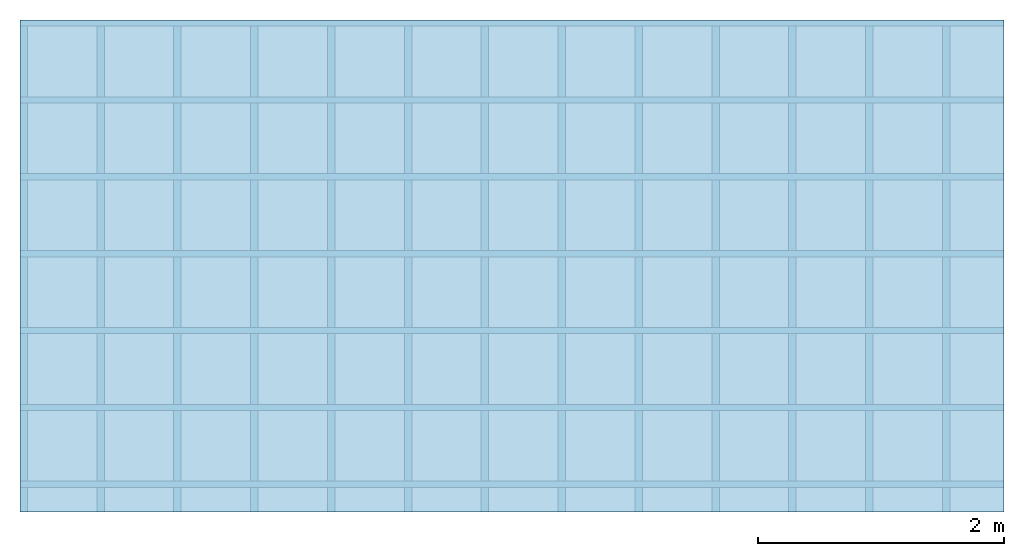
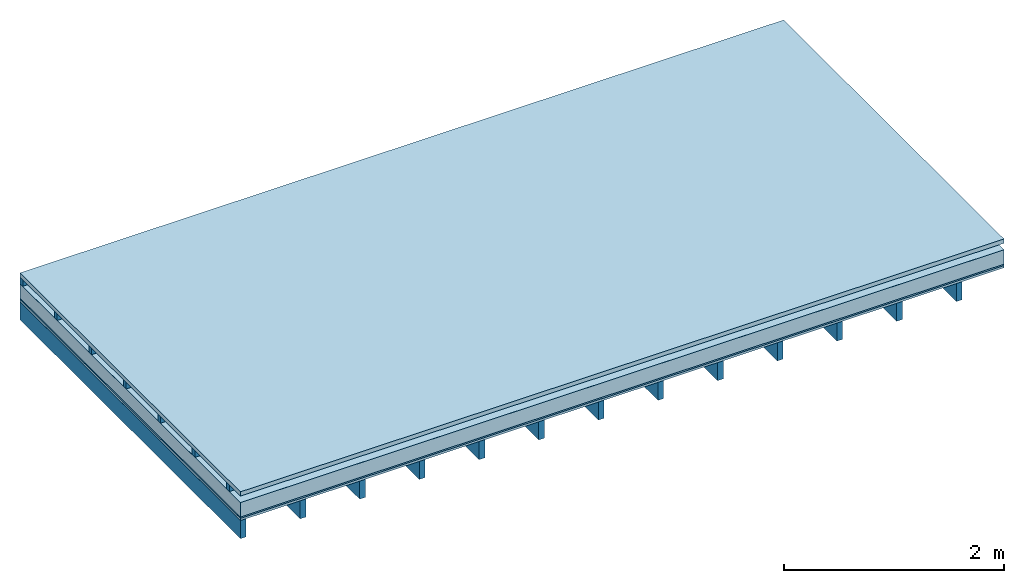
# One storey: 5 plates, 2 members, 1 element without a shape of its own.
"""IFC4 building model written with IfcOpenShell, lengths in metres."""

from ifc_helpers import new_model, si_unit, derived_unit, direction, frame, frame_2d, origin, origin_with_axes, place, context, project, spatial, rectangle, extrude, material, layer, layer_set, type_object, element, aggregate, save


model = new_model("IFC4")

# Units and contexts
plan_context = context("Plan", 3, precision=1e-05, world=origin(), true_north=direction((0.0, 1.0)))
model_context = context("Model", 3, precision=1e-05, world=origin(), true_north=direction((0.0, 1.0)))
ifc_project = project(units=[si_unit("LENGTHUNIT", "METRE"), derived_unit("SOUNDPRESSUREUNIT", [(si_unit("PRESSUREUNIT", "PASCAL", prefix="MICRO"), 0)]), si_unit("ENERGYUNIT", "JOULE", prefix="MEGA"), si_unit("MASSUNIT", "GRAM", prefix="KILO"), derived_unit("THERMALTRANSMITTANCEUNIT", [(si_unit("POWERUNIT", "WATT"), 1), (si_unit("AREAUNIT", "SQUARE_METRE"), -1), (si_unit("THERMODYNAMICTEMPERATUREUNIT", "KELVIN"), -1)]), derived_unit("AREADENSITYUNIT", [(si_unit("MASSUNIT", "GRAM", prefix="KILO"), 1), (si_unit("AREAUNIT", "SQUARE_METRE"), -1)]), derived_unit("USERDEFINED", [(si_unit("ENERGYUNIT", "JOULE", prefix="MEGA"), 1), (si_unit("AREAUNIT", "SQUARE_METRE"), -1)])], contexts=[plan_context, model_context])

# Site, building, storey
site = spatial("IfcSite", under=ifc_project)
building_placement = place(None, origin())
building = spatial("IfcBuilding", under=site, at=building_placement)
storey_placement = place(building_placement, origin())
storey = spatial("IfcBuildingStorey", under=building, at=storey_placement)

# Slab, members, plates
ifc_material_1 = material(Name="Roof tiles", Category="03.015")
ifc_layer_1 = layer(ifc_material_1, 0.047, Name="Roofing")
ifc_layer_2 = layer(None, 0.072, Name="Battens / profiles")
ifc_material_2 = material(Name="Roofing underlay", Category="09.008")
ifc_layer_3 = layer(ifc_material_2, 0.00018, Name="Under the roof")
ifc_material_3 = material(Category="10.008")
ifc_layer_4 = layer(ifc_material_3, 0.16, Name="Exterior insulation layer 1")
ifc_material_4 = material(Category="03.007")
ifc_layer_5 = layer(ifc_material_4, 0.015, Name="above 1st layer")
ifc_material_5 = material(Category="07.001")
ifc_layer_6 = layer(ifc_material_5, 0.025, Name="Sub-floor")
ifc_material_6 = material(Name="of the art")
ifc_layer_7 = layer(ifc_material_6, 0.0, Name="Bond")
ifc_layer_8 = layer(None, 0.2, Name="Supporting structure")
ifc_layer_set = layer_set([ifc_layer_1, ifc_layer_2, ifc_layer_3, ifc_layer_4, ifc_layer_5, ifc_layer_6, ifc_layer_7, ifc_layer_8])
slab_type = type_object("IfcSlabType", Name="E0062", PredefinedType="NOTDEFINED", material=ifc_layer_set)
slab_placement = place(None, frame((0.0, 0.0, 0.0), z_axis=(0.0, 0.0, -1.0), x_axis=(1.0, 0.0, 0.0)))
slab = element("IfcSlab", 1, at=slab_placement, inside=storey, type_object=slab_type, material=ifc_layer_set, Name="Slab #1")
ifc_material_7 = material()
member_1_placement = place(slab_placement, origin())
member_1 = element("IfcMember", 2, at=member_1_placement, material=ifc_material_7, Name="Battens / profiles", context=plan_context, shape_type="SweptSolid", body=[
    extrude(rectangle(XDim=0.05, YDim=0.072, at=frame_2d((0.025, 0.036), x_axis=(1.0, 0.0))), frame((0.0, 0.0, 0.047), z_axis=(1.0, 0.0, 0.0), x_axis=(0.0, 1.0, 0.0)), (0.0, 0.0, 1.0), 8.0),
    extrude(rectangle(XDim=0.05, YDim=0.072, at=frame_2d((0.025, 0.036), x_axis=(1.0, 0.0))), frame((0.0, 0.625, 0.047), z_axis=(1.0, 0.0, 0.0), x_axis=(0.0, 1.0, 0.0)), (0.0, 0.0, 1.0), 8.0),
    extrude(rectangle(XDim=0.05, YDim=0.072, at=frame_2d((0.025, 0.036), x_axis=(1.0, 0.0))), frame((0.0, 1.25, 0.047), z_axis=(1.0, 0.0, 0.0), x_axis=(0.0, 1.0, 0.0)), (0.0, 0.0, 1.0), 8.0),
    extrude(rectangle(XDim=0.05, YDim=0.072, at=frame_2d((0.025, 0.036), x_axis=(1.0, 0.0))), frame((0.0, 1.875, 0.047), z_axis=(1.0, 0.0, 0.0), x_axis=(0.0, 1.0, 0.0)), (0.0, 0.0, 1.0), 8.0),
    extrude(rectangle(XDim=0.05, YDim=0.072, at=frame_2d((0.025, 0.036), x_axis=(1.0, 0.0))), frame((0.0, 2.5, 0.047), z_axis=(1.0, 0.0, 0.0), x_axis=(0.0, 1.0, 0.0)), (0.0, 0.0, 1.0), 8.0),
    extrude(rectangle(XDim=0.05, YDim=0.072, at=frame_2d((0.025, 0.036), x_axis=(1.0, 0.0))), frame((0.0, 3.125, 0.047), z_axis=(1.0, 0.0, 0.0), x_axis=(0.0, 1.0, 0.0)), (0.0, 0.0, 1.0), 8.0),
    extrude(rectangle(XDim=0.05, YDim=0.072, at=frame_2d((0.025, 0.036), x_axis=(1.0, 0.0))), frame((0.0, 3.75, 0.047), z_axis=(1.0, 0.0, 0.0), x_axis=(0.0, 1.0, 0.0)), (0.0, 0.0, 1.0), 8.0),
])
ifc_material_8 = material()
member_2_placement = place(slab_placement, origin())
member_2 = element("IfcMember", 3, at=member_2_placement, material=ifc_material_8, Name="Supporting structure", context=plan_context, shape_type="SweptSolid", body=[
    extrude(rectangle(XDim=0.06, YDim=0.2, at=frame_2d((0.03, 0.1), x_axis=(1.0, 0.0))), frame((0.0, 4.0, 0.31918), z_axis=(0.0, -1.0, 0.0), x_axis=(1.0, 0.0, 0.0)), (0.0, 0.0, 1.0), 4.0),
    extrude(rectangle(XDim=0.06, YDim=0.2, at=frame_2d((0.03, 0.1), x_axis=(1.0, 0.0))), frame((0.625, 4.0, 0.31918), z_axis=(0.0, -1.0, 0.0), x_axis=(1.0, 0.0, 0.0)), (0.0, 0.0, 1.0), 4.0),
    extrude(rectangle(XDim=0.06, YDim=0.2, at=frame_2d((0.03, 0.1), x_axis=(1.0, 0.0))), frame((1.25, 4.0, 0.31918), z_axis=(0.0, -1.0, 0.0), x_axis=(1.0, 0.0, 0.0)), (0.0, 0.0, 1.0), 4.0),
    extrude(rectangle(XDim=0.06, YDim=0.2, at=frame_2d((0.03, 0.1), x_axis=(1.0, 0.0))), frame((1.875, 4.0, 0.31918), z_axis=(0.0, -1.0, 0.0), x_axis=(1.0, 0.0, 0.0)), (0.0, 0.0, 1.0), 4.0),
    extrude(rectangle(XDim=0.06, YDim=0.2, at=frame_2d((0.03, 0.1), x_axis=(1.0, 0.0))), frame((2.5, 4.0, 0.31918), z_axis=(0.0, -1.0, 0.0), x_axis=(1.0, 0.0, 0.0)), (0.0, 0.0, 1.0), 4.0),
    extrude(rectangle(XDim=0.06, YDim=0.2, at=frame_2d((0.03, 0.1), x_axis=(1.0, 0.0))), frame((3.125, 4.0, 0.31918), z_axis=(0.0, -1.0, 0.0), x_axis=(1.0, 0.0, 0.0)), (0.0, 0.0, 1.0), 4.0),
    extrude(rectangle(XDim=0.06, YDim=0.2, at=frame_2d((0.03, 0.1), x_axis=(1.0, 0.0))), frame((3.75, 4.0, 0.31918), z_axis=(0.0, -1.0, 0.0), x_axis=(1.0, 0.0, 0.0)), (0.0, 0.0, 1.0), 4.0),
    extrude(rectangle(XDim=0.06, YDim=0.2, at=frame_2d((0.03, 0.1), x_axis=(1.0, 0.0))), frame((4.375, 4.0, 0.31918), z_axis=(0.0, -1.0, 0.0), x_axis=(1.0, 0.0, 0.0)), (0.0, 0.0, 1.0), 4.0),
    extrude(rectangle(XDim=0.06, YDim=0.2, at=frame_2d((0.03, 0.1), x_axis=(1.0, 0.0))), frame((5.0, 4.0, 0.31918), z_axis=(0.0, -1.0, 0.0), x_axis=(1.0, 0.0, 0.0)), (0.0, 0.0, 1.0), 4.0),
    extrude(rectangle(XDim=0.06, YDim=0.2, at=frame_2d((0.03, 0.1), x_axis=(1.0, 0.0))), frame((5.625, 4.0, 0.31918), z_axis=(0.0, -1.0, 0.0), x_axis=(1.0, 0.0, 0.0)), (0.0, 0.0, 1.0), 4.0),
    extrude(rectangle(XDim=0.06, YDim=0.2, at=frame_2d((0.03, 0.1), x_axis=(1.0, 0.0))), frame((6.25, 4.0, 0.31918), z_axis=(0.0, -1.0, 0.0), x_axis=(1.0, 0.0, 0.0)), (0.0, 0.0, 1.0), 4.0),
    extrude(rectangle(XDim=0.06, YDim=0.2, at=frame_2d((0.03, 0.1), x_axis=(1.0, 0.0))), frame((6.875, 4.0, 0.31918), z_axis=(0.0, -1.0, 0.0), x_axis=(1.0, 0.0, 0.0)), (0.0, 0.0, 1.0), 4.0),
    extrude(rectangle(XDim=0.06, YDim=0.2, at=frame_2d((0.03, 0.1), x_axis=(1.0, 0.0))), frame((7.5, 4.0, 0.31918), z_axis=(0.0, -1.0, 0.0), x_axis=(1.0, 0.0, 0.0)), (0.0, 0.0, 1.0), 4.0),
])
plate_1_placement = place(slab_placement, origin())
plate_1 = element("IfcPlate", 4, at=plate_1_placement, material=ifc_material_1, Name="Roofing", context=plan_context, shape_type="SweptSolid", body=[
    extrude(rectangle(XDim=8.0, YDim=4.0, at=frame_2d((4.0, 2.0), x_axis=(1.0, 0.0))), origin_with_axes(), (0.0, 0.0, 1.0), 0.047),
])
plate_2_placement = place(slab_placement, origin())
plate_2 = element("IfcPlate", 5, at=plate_2_placement, material=ifc_material_2, Name="Under the roof", context=plan_context, shape_type="SweptSolid", body=[
    extrude(rectangle(XDim=8.0, YDim=4.0, at=frame_2d((4.0, 2.0), x_axis=(1.0, 0.0))), frame((0.0, 0.0, 0.119), z_axis=(0.0, 0.0, 1.0), x_axis=(1.0, 0.0, 0.0)), (0.0, 0.0, 1.0), 0.00018),
])
plate_3_placement = place(slab_placement, origin())
plate_3 = element("IfcPlate", 6, at=plate_3_placement, material=ifc_material_3, Name="Exterior insulation layer 1", context=plan_context, shape_type="SweptSolid", body=[
    extrude(rectangle(XDim=8.0, YDim=4.0, at=frame_2d((4.0, 2.0), x_axis=(1.0, 0.0))), frame((0.0, 0.0, 0.11918), z_axis=(0.0, 0.0, 1.0), x_axis=(1.0, 0.0, 0.0)), (0.0, 0.0, 1.0), 0.16),
])
plate_4_placement = place(slab_placement, origin())
plate_4 = element("IfcPlate", 7, at=plate_4_placement, material=ifc_material_4, Name="above 1st layer", context=plan_context, shape_type="SweptSolid", body=[
    extrude(rectangle(XDim=8.0, YDim=4.0, at=frame_2d((4.0, 2.0), x_axis=(1.0, 0.0))), frame((0.0, 0.0, 0.27918), z_axis=(0.0, 0.0, 1.0), x_axis=(1.0, 0.0, 0.0)), (0.0, 0.0, 1.0), 0.015),
])
plate_5_placement = place(slab_placement, origin())
plate_5 = element("IfcPlate", 8, at=plate_5_placement, material=ifc_material_5, Name="Sub-floor", context=plan_context, shape_type="SweptSolid", body=[
    extrude(rectangle(XDim=8.0, YDim=4.0, at=frame_2d((4.0, 2.0), x_axis=(1.0, 0.0))), frame((0.0, 0.0, 0.29418), z_axis=(0.0, 0.0, 1.0), x_axis=(1.0, 0.0, 0.0)), (0.0, 0.0, 1.0), 0.025),
])
aggregate(slab, [plate_1, member_1, plate_2, plate_3, plate_4, plate_5, member_2])

save(model, "model.ifc")
